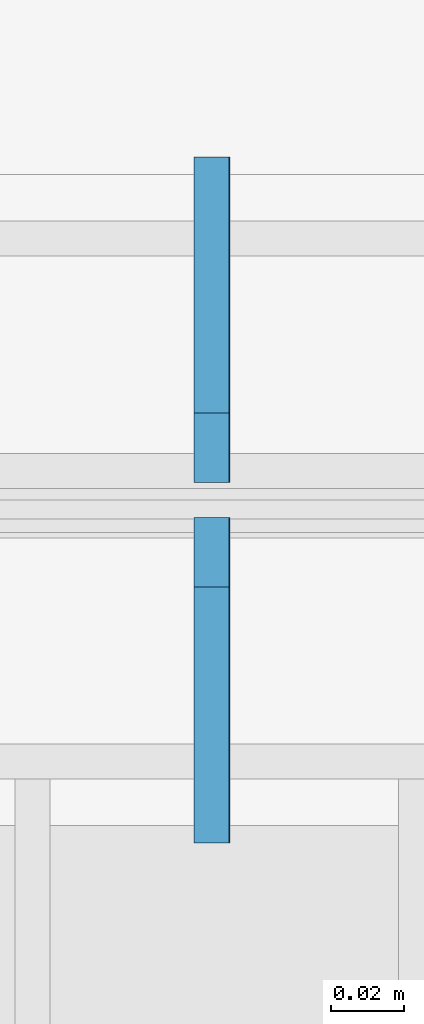
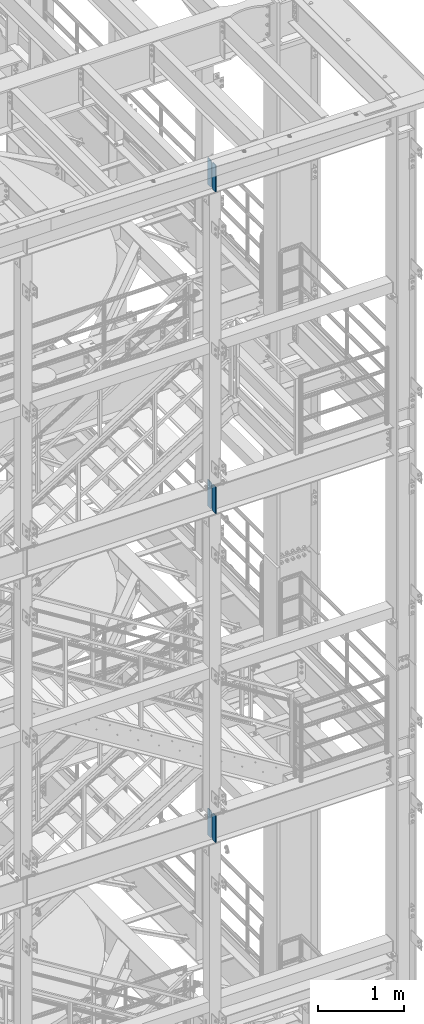
# One storey, part 1448 of 1876: 6 plates, 3 elements without a shape of their own.
"""IFC2X3 building model written with IfcOpenShell, lengths in millimetres."""

from ifc_helpers import new_model, si_unit, frame, origin_with_axes, place, context, subcontext, project, spatial, faceted_brep, material, type_object, element, aggregate, save


model = new_model("IFC2X3")

# Units and contexts
model_context = context("Model", 3, precision=1e-05, world=origin_with_axes())
body_context = subcontext(model_context, "Body", "Model", "MODEL_VIEW")
ifc_project = project(units=[si_unit("LENGTHUNIT", "METRE", prefix="MILLI"), si_unit("AREAUNIT", "SQUARE_METRE"), si_unit("VOLUMEUNIT", "CUBIC_METRE"), si_unit("MASSUNIT", "GRAM", prefix="KILO"), si_unit("TIMEUNIT", "SECOND"), si_unit("PLANEANGLEUNIT", "RADIAN"), si_unit("SOLIDANGLEUNIT", "STERADIAN"), si_unit("THERMODYNAMICTEMPERATUREUNIT", "DEGREE_CELSIUS"), si_unit("LUMINOUSINTENSITYUNIT", "LUMEN")], contexts=[model_context])

# Site, building, storey
site_placement = place(None, origin_with_axes())
site = spatial("IfcSite", under=ifc_project, at=site_placement, CompositionType="ELEMENT")
building_placement = place(site_placement, origin_with_axes())
building = spatial("IfcBuilding", under=site, at=building_placement, Name="Undefined", CompositionType="ELEMENT")
storey_placement = place(building_placement, origin_with_axes())
storey = spatial("IfcBuildingStorey", under=building, at=storey_placement, Name="Undefined", CompositionType="ELEMENT", Elevation=0.0)

# Assembly, plates
assembly_1_placement = place(storey_placement, origin_with_axes())
assembly_1 = element("IfcElementAssembly", 1, at=assembly_1_placement, inside=storey, Name="BEAM", AssemblyPlace="NOTDEFINED", PredefinedType="RIGID_FRAME")
ifc_material = material(Name="STEEL/A36")
plate_type = type_object("IfcPlateType", PredefinedType="NOTDEFINED")
plate_1_placement = place(assembly_1_placement, frame((5079.71425401922, -7205.6625, 22159.9125), z_axis=(0.0, 0.0, 1.0), x_axis=(0.0, 1.0, 0.0)))
plate_1 = element("IfcPlate", 2, at=plate_1_placement, type_object=plate_type, material=ifc_material, Name="PLATE", context=body_context, shape_type="Brep", body=[
    faceted_brep([(0.0, -4.76249999999982, 0.0), (0.0, -4.76250000000073, 381.0), (0.0, 4.76250000000073, 381.0), (0.0, 4.76249999999982, 0.0), (69.8500022888184, -4.76249999999982, 381.0), (69.8500022888184, 4.76249999999982, 381.0), (88.9000015258789, -4.76249999999982, 361.950000762939), (88.9000015258789, 4.76249999999982, 361.950000762939), (88.9000015258789, -4.76249999999982, 19.0499992370605), (88.9000015258789, 4.76249999999982, 19.0499992370605), (69.8500022888184, -4.76249999999982, 0.0), (69.8500022888184, 4.76249999999982, 0.0)], [[[0, 1, 2, 3]], [[1, 4, 5, 2]], [[4, 6, 7, 5]], [[6, 8, 9, 7]], [[8, 10, 11, 9]], [[10, 0, 3, 11]], [[5, 7, 9, 11, 3, 2]], [[10, 8, 6, 4, 1, 0]]]),
])
plate_2_placement = place(assembly_1_placement, frame((5079.71425401922, -7107.2375, 22159.9125), z_axis=(0.0, 0.0, 1.0), x_axis=(0.0, 1.0, 0.0)))
plate_2 = element("IfcPlate", 3, at=plate_2_placement, type_object=plate_type, material=ifc_material, Name="PLATE", context=body_context, shape_type="Brep", body=[
    faceted_brep([(0.0, -4.76249999999982, 19.0499992370605), (0.0, -4.76249999999982, 361.950000762939), (0.0, 4.76249999999982, 361.950000762939), (0.0, 4.76249999999982, 19.0499992370605), (19.0499992370605, -4.76249999999982, 381.0), (19.0499992370605, 4.76249999999982, 381.0), (88.9000015258789, -4.76249999999982, 381.0), (88.9000015258789, 4.76249999999982, 381.0), (88.9000015258789, -4.76249999999982, 0.0), (88.9000015258789, 4.76249999999982, 0.0), (19.0499992370605, -4.76249999999982, 0.0), (19.0499992370605, 4.76249999999982, 0.0)], [[[0, 1, 2, 3]], [[1, 4, 5, 2]], [[4, 6, 7, 5]], [[6, 8, 9, 7]], [[8, 10, 11, 9]], [[10, 0, 3, 11]], [[5, 7, 9, 11, 3, 2]], [[10, 8, 6, 4, 1, 0]]]),
])
aggregate(assembly_1, [plate_1, plate_2])

assembly_2_placement = place(storey_placement, origin_with_axes())
assembly_2 = element("IfcElementAssembly", 4, at=assembly_2_placement, inside=storey, Name="BEAM", AssemblyPlace="NOTDEFINED", PredefinedType="RIGID_FRAME")
plate_3_placement = place(assembly_2_placement, frame((5079.71425401922, -7205.6625, 17587.9125), z_axis=(0.0, 0.0, 1.0), x_axis=(0.0, 1.0, 0.0)))
plate_3 = element("IfcPlate", 5, at=plate_3_placement, type_object=plate_type, material=ifc_material, Name="PLATE", context=body_context, shape_type="Brep", body=[
    faceted_brep([(0.0, -4.76249999999982, 0.0), (0.0, -4.76250000000073, 381.0), (0.0, 4.76250000000073, 381.0), (0.0, 4.76249999999982, 0.0), (69.8500022888184, -4.76249999999982, 381.0), (69.8500022888184, 4.76249999999982, 381.0), (88.9000015258789, -4.76249999999982, 361.950000762939), (88.9000015258789, 4.76249999999982, 361.950000762939), (88.9000015258789, -4.76249999999982, 19.0499992370605), (88.9000015258789, 4.76249999999982, 19.0499992370605), (69.8500022888184, -4.76249999999982, 0.0), (69.8500022888184, 4.76249999999982, 0.0)], [[[0, 1, 2, 3]], [[1, 4, 5, 2]], [[4, 6, 7, 5]], [[6, 8, 9, 7]], [[8, 10, 11, 9]], [[10, 0, 3, 11]], [[5, 7, 9, 11, 3, 2]], [[10, 8, 6, 4, 1, 0]]]),
])
plate_4_placement = place(assembly_2_placement, frame((5079.71425401922, -7107.2375, 17587.9125), z_axis=(0.0, 0.0, 1.0), x_axis=(0.0, 1.0, 0.0)))
plate_4 = element("IfcPlate", 6, at=plate_4_placement, type_object=plate_type, material=ifc_material, Name="PLATE", context=body_context, shape_type="Brep", body=[
    faceted_brep([(0.0, -4.76249999999982, 19.0499992370605), (0.0, -4.76249999999982, 361.950000762939), (0.0, 4.76249999999982, 361.950000762939), (0.0, 4.76249999999982, 19.0499992370605), (19.0499992370605, -4.76249999999982, 381.0), (19.0499992370605, 4.76249999999982, 381.0), (88.9000015258789, -4.76249999999982, 381.0), (88.9000015258789, 4.76249999999982, 381.0), (88.9000015258789, -4.76249999999982, 0.0), (88.9000015258789, 4.76249999999982, 0.0), (19.0499992370605, -4.76249999999982, 0.0), (19.0499992370605, 4.76249999999982, 0.0)], [[[0, 1, 2, 3]], [[1, 4, 5, 2]], [[4, 6, 7, 5]], [[6, 8, 9, 7]], [[8, 10, 11, 9]], [[10, 0, 3, 11]], [[5, 7, 9, 11, 3, 2]], [[10, 8, 6, 4, 1, 0]]]),
])
aggregate(assembly_2, [plate_3, plate_4])

assembly_3_placement = place(storey_placement, origin_with_axes())
assembly_3 = element("IfcElementAssembly", 7, at=assembly_3_placement, inside=storey, Name="BEAM", AssemblyPlace="NOTDEFINED", PredefinedType="RIGID_FRAME")
plate_5_placement = place(assembly_3_placement, frame((5080.0, -7205.6625, 12914.3125), z_axis=(0.0, 0.0, 1.0), x_axis=(0.0, 1.0, 0.0)))
plate_5 = element("IfcPlate", 8, at=plate_5_placement, type_object=plate_type, material=ifc_material, Name="PLATE", context=body_context, shape_type="Brep", body=[
    faceted_brep([(0.0, -4.76249999999982, 0.0), (0.0, -4.76250000000073, 381.0), (0.0, 4.76250000000073, 381.0), (0.0, 4.76249999999982, 0.0), (69.8500022888184, -4.76249999999982, 381.0), (69.8500022888184, 4.76249999999982, 381.0), (88.9000015258789, -4.76249999999982, 361.950000762939), (88.9000015258789, 4.76249999999982, 361.950000762939), (88.9000015258789, -4.76249999999982, 19.0499992370605), (88.9000015258789, 4.76249999999982, 19.0499992370605), (69.8500022888184, -4.76249999999982, 0.0), (69.8500022888184, 4.76249999999982, 0.0)], [[[0, 1, 2, 3]], [[1, 4, 5, 2]], [[4, 6, 7, 5]], [[6, 8, 9, 7]], [[8, 10, 11, 9]], [[10, 0, 3, 11]], [[5, 7, 9, 11, 3, 2]], [[10, 8, 6, 4, 1, 0]]]),
])
plate_6_placement = place(assembly_3_placement, frame((5080.0, -7107.2375, 12914.3125), z_axis=(0.0, 0.0, 1.0), x_axis=(0.0, 1.0, 0.0)))
plate_6 = element("IfcPlate", 9, at=plate_6_placement, type_object=plate_type, material=ifc_material, Name="PLATE", context=body_context, shape_type="Brep", body=[
    faceted_brep([(0.0, -4.76249999999982, 19.0499992370605), (0.0, -4.76249999999982, 361.950000762939), (0.0, 4.76249999999982, 361.950000762939), (0.0, 4.76249999999982, 19.0499992370605), (19.0499992370605, -4.76249999999982, 381.0), (19.0499992370605, 4.76249999999982, 381.0), (88.9000015258789, -4.76249999999982, 381.0), (88.9000015258789, 4.76249999999982, 381.0), (88.9000015258789, -4.76249999999982, 0.0), (88.9000015258789, 4.76249999999982, 0.0), (19.0499992370605, -4.76249999999982, 0.0), (19.0499992370605, 4.76249999999982, 0.0)], [[[0, 1, 2, 3]], [[1, 4, 5, 2]], [[4, 6, 7, 5]], [[6, 8, 9, 7]], [[8, 10, 11, 9]], [[10, 0, 3, 11]], [[5, 7, 9, 11, 3, 2]], [[10, 8, 6, 4, 1, 0]]]),
])
aggregate(assembly_3, [plate_5, plate_6])

save(model, "model.ifc")
